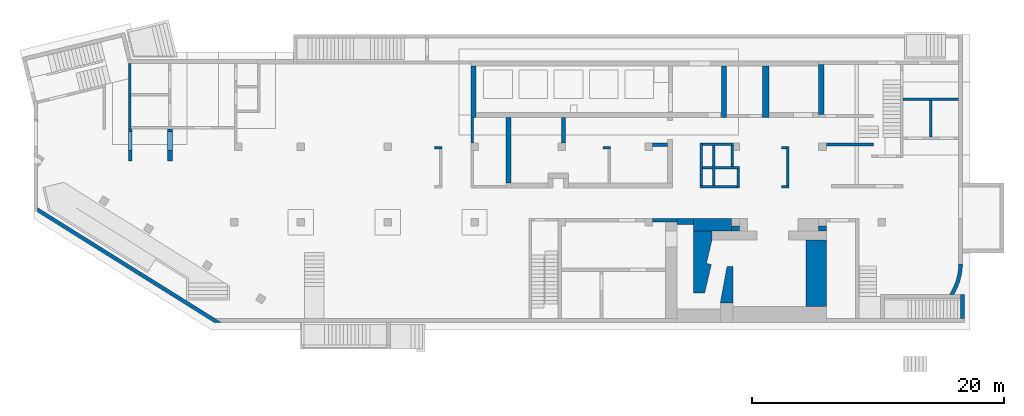
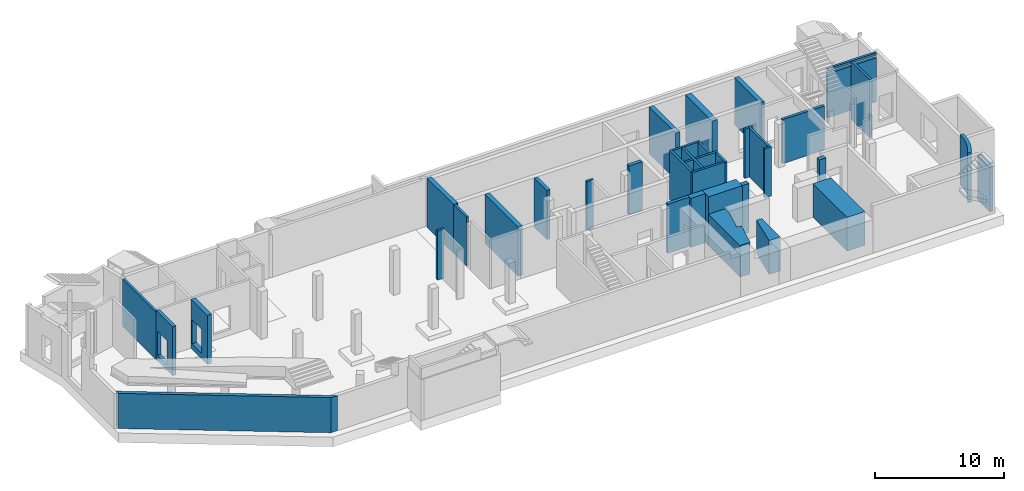
# One storey, part 3 of 9: 37 walls, 4 openings.
"""IFC4 building model written with IfcOpenShell, lengths in millimetres."""

from ifc_helpers import new_model, entity, si_unit, converted_unit, derived_unit, direction, frame, origin, place, context, subcontext, project, spatial, indexed_curve, outline, extrude, polygons, material, type_object, element, save


model = new_model("IFC4")

# Units and contexts
model_context = context("Model", 3, precision=0.01, world=origin(), true_north=direction((6.12303176911189e-17, 1.0)))
plan_context = context("Plan", 3, precision=0.01, world=origin(), true_north=direction((6.12303176911189e-17, 1.0)))
body_context = subcontext(model_context, "Body", "Model", "MODEL_VIEW")
ifc_project = project(units=[si_unit("LENGTHUNIT", "METRE", prefix="MILLI"), si_unit("AREAUNIT", "SQUARE_METRE"), si_unit("VOLUMEUNIT", "CUBIC_METRE"), converted_unit("PLANEANGLEUNIT", "DEGREE", entity("IfcRatioMeasure", 0.0174532925199433), si_unit("PLANEANGLEUNIT", "RADIAN"), dimensions=[0, 0, 0, 0, 0, 0, 0]), si_unit("MASSUNIT", "GRAM", prefix="KILO"), derived_unit("MASSDENSITYUNIT", [(si_unit("MASSUNIT", "GRAM", prefix="KILO"), 1), (si_unit("LENGTHUNIT", "METRE"), -3)]), derived_unit("MOMENTOFINERTIAUNIT", [(si_unit("LENGTHUNIT", "METRE"), 4)]), si_unit("TIMEUNIT", "SECOND"), si_unit("FREQUENCYUNIT", "HERTZ"), si_unit("THERMODYNAMICTEMPERATUREUNIT", "DEGREE_CELSIUS"), derived_unit("THERMALTRANSMITTANCEUNIT", [(si_unit("MASSUNIT", "GRAM", prefix="KILO"), 1), (si_unit("THERMODYNAMICTEMPERATUREUNIT", "KELVIN"), -1), (si_unit("TIMEUNIT", "SECOND"), -3)]), derived_unit("VOLUMETRICFLOWRATEUNIT", [(si_unit("LENGTHUNIT", "METRE"), 3), (si_unit("TIMEUNIT", "SECOND"), -1)]), derived_unit("MASSFLOWRATEUNIT", [(si_unit("MASSUNIT", "GRAM", prefix="KILO"), 1), (si_unit("TIMEUNIT", "SECOND"), -1)]), derived_unit("ROTATIONALFREQUENCYUNIT", [(si_unit("TIMEUNIT", "SECOND"), -1)]), si_unit("ELECTRICCURRENTUNIT", "AMPERE"), si_unit("ELECTRICVOLTAGEUNIT", "VOLT"), si_unit("POWERUNIT", "WATT"), si_unit("FORCEUNIT", "NEWTON", prefix="KILO"), si_unit("ILLUMINANCEUNIT", "LUX"), si_unit("LUMINOUSFLUXUNIT", "LUMEN"), si_unit("LUMINOUSINTENSITYUNIT", "CANDELA"), derived_unit("USERDEFINED", [(si_unit("MASSUNIT", "GRAM", prefix="KILO"), -1), (si_unit("LENGTHUNIT", "METRE"), -2), (si_unit("TIMEUNIT", "SECOND"), 3), (si_unit("LUMINOUSFLUXUNIT", "LUMEN"), 1)]), derived_unit("LINEARVELOCITYUNIT", [(si_unit("LENGTHUNIT", "METRE"), 1), (si_unit("TIMEUNIT", "SECOND"), -1)]), si_unit("PRESSUREUNIT", "PASCAL"), derived_unit("USERDEFINED", [(si_unit("LENGTHUNIT", "METRE"), -2), (si_unit("MASSUNIT", "GRAM", prefix="KILO"), 1), (si_unit("TIMEUNIT", "SECOND"), -2)]), derived_unit("LINEARFORCEUNIT", [(si_unit("MASSUNIT", "GRAM", prefix="KILO"), 1), (si_unit("LENGTHUNIT", "METRE"), 1), (si_unit("TIMEUNIT", "SECOND"), -2), (si_unit("LENGTHUNIT", "METRE"), -1)]), derived_unit("PLANARFORCEUNIT", [(si_unit("MASSUNIT", "GRAM", prefix="KILO"), 1), (si_unit("LENGTHUNIT", "METRE"), 1), (si_unit("TIMEUNIT", "SECOND"), -2), (si_unit("LENGTHUNIT", "METRE"), -2)])], contexts=[model_context, plan_context])

# Site, building, storey
site_placement = place(None, origin())
site = spatial("IfcSite", under=ifc_project, at=site_placement, CompositionType="ELEMENT")
building_placement = place(site_placement, origin())
building = spatial("IfcBuilding", under=site, at=building_placement, CompositionType="ELEMENT")
storey_placement = place(building_placement, frame((0.0, 0.0, -4900.0)))
storey = spatial("IfcBuildingStorey", under=building, at=storey_placement, CompositionType="ELEMENT", Elevation=-4900.0)

# Wall, opening
ifc_material = material()
wall_type_1 = type_object("IfcWallType", PredefinedType="STANDARD")
wall_1_placement = place(storey_placement, frame((73370.0002685547, 17469.9992263554, 0.0), z_axis=(0.0, 0.0, 1.0), x_axis=(-1.0, 0.0, 0.0)))
wall_1 = element("IfcWall", 1, at=wall_1_placement, inside=storey, type_object=wall_type_1, material=ifc_material, PredefinedType="NOTDEFINED", context=body_context, shape_type="SweptSolid", body=[
    extrude(outline(indexed_curve([(4399.99999999998, 99.9999999999989), (-3.44548696094126e-13, 99.9999999999989), (3.44548696094126e-13, -99.9999999999989), (4399.99999999998, -99.9999999999989), (4399.99999999998, 99.9999999999989)], self_intersect=False)), origin(), (0.0, 0.0, 1.0), 4650.0),
])
opening_1_placement = place(storey_placement, frame((73370.0002685547, 17469.9992263554, 0.0), z_axis=(0.0, 0.0, 1.0), x_axis=(-1.0, 0.0, 0.0)))
element("IfcOpeningElement", 2, at=opening_1_placement, cuts=wall_1, PredefinedType="OPENING", context=body_context, shape_type="SweptSolid", body=[
    extrude(outline(indexed_curve([(-2199.99999999998, -100.0), (2199.99999999999, -100.0), (2199.99999999999, 100.0), (-2199.99999999999, 100.0), (-2199.99999999998, -100.0)], self_intersect=False)), frame((2200.0, 0.0, 4170.0)), (0.0, 0.0, 1.0), 250.0),
])

# Walls
wall_2_placement = place(storey_placement, frame((71170.0002685547, 14469.9992263559, -850.0), z_axis=(0.0, 0.0, 1.0), x_axis=(0.0, 1.0, 0.0)))
element("IfcWall", 3, at=wall_2_placement, inside=storey, type_object=wall_type_1, material=ifc_material, PredefinedType="NOTDEFINED", context=body_context, shape_type="SweptSolid", body=[
    extrude(outline(indexed_curve([(2899.99999999951, 100.000000000003), (-2.98721966703065e-13, 100.000000000003), (2.98721966703065e-13, -100.000000000003), (2899.99999999951, -100.000000000003), (2899.99999999951, 100.000000000003)], self_intersect=False)), origin(), (0.0, 0.0, 1.0), 5500.0),
])
wall_3_placement = place(storey_placement, frame((34770.0002685547, 15999.9992263561, 0.0), z_axis=(0.0, 0.0, 1.0), x_axis=(0.0, -1.0, 0.0)))
element("IfcWall", 4, at=wall_3_placement, inside=storey, type_object=wall_type_1, material=ifc_material, PredefinedType="NOTDEFINED", context=body_context, shape_type="SweptSolid", body=[
    extrude(outline(indexed_curve([(1999.99999999982, 99.9999999999989), (-2.16573425859696e-13, 99.9999999999989), (2.16573425859696e-13, -99.9999999999989), (1999.99999999982, -99.9999999999989), (1999.99999999982, 99.9999999999989)], self_intersect=False)), origin(), (0.0, 0.0, 1.0), 4650.0),
])
wall_4_placement = place(storey_placement, frame((59830.0002685547, 10624.999226356, 0.0), z_axis=(0.0, 0.0, 1.0), x_axis=(0.0, 1.0, 0.0)))
element("IfcWall", 5, at=wall_4_placement, inside=storey, type_object=wall_type_1, material=ifc_material, PredefinedType="NOTDEFINED", context=body_context, shape_type="SweptSolid", body=[
    extrude(outline(indexed_curve([(3075.0, 100.000000000004), (-3.08123216157509e-13, 100.000000000003), (3.08123216157509e-13, -100.000000000003), (3075.0, -100.000000000002), (3075.0, 100.000000000004)], self_intersect=False)), origin(), (0.0, 0.0, 1.0), 4650.0),
])
wall_5_placement = place(storey_placement, frame((59730.0002685547, 13599.999226356, 0.0), z_axis=(0.0, 0.0, 1.0), x_axis=(-1.0, 0.0, 0.0)))
element("IfcWall", 6, at=wall_5_placement, inside=storey, type_object=wall_type_1, material=ifc_material, PredefinedType="NOTDEFINED", context=body_context, shape_type="SweptSolid", body=[
    extrude(outline(indexed_curve([(400.000000000003, 99.9999999999983), (-9.28211303758498e-13, 99.9999999999989), (9.28211303758498e-13, -99.9999999999989), (400.000000000005, -99.9999999999995), (400.000000000003, 99.9999999999983)], self_intersect=False)), origin(), (0.0, 0.0, 1.0), 4650.0),
])
wall_6_placement = place(storey_placement, frame((59930.0002685546, 10524.999226356, 0.0), z_axis=(0.0, 0.0, 1.0), x_axis=(-1.0, 0.0, 0.0)))
element("IfcWall", 7, at=wall_6_placement, inside=storey, type_object=wall_type_1, material=ifc_material, PredefinedType="NOTDEFINED", context=body_context, shape_type="SweptSolid", body=[
    extrude(outline(indexed_curve([(600.00000000001, 99.999999999998), (-9.28211303758498e-13, 99.9999999999989), (9.28211303758498e-13, -99.9999999999989), (600.000000000012, -99.9999999999999), (600.00000000001, 99.999999999998)], self_intersect=False)), origin(), (0.0, 0.0, 1.0), 4650.0),
])
wall_7_placement = place(storey_placement, frame((55520.0002685546, 13899.9992263562, 0.0), z_axis=(0.0, 0.0, 1.0), x_axis=(-1.0, 0.0, 0.0)))
element("IfcWall", 8, at=wall_7_placement, inside=storey, type_object=wall_type_1, material=ifc_material, PredefinedType="NOTDEFINED", context=body_context, shape_type="SweptSolid", body=[
    extrude(outline(indexed_curve([(2470.00000000003, 100.000000000001), (-3.39529745858372e-13, 99.9999999999989), (3.39529745858372e-13, -99.9999999999989), (2470.00000000003, -99.999999999997), (2470.00000000003, 100.000000000001)], self_intersect=False)), origin(), (0.0, 0.0, 1.0), 4650.0),
])
wall_8_placement = place(storey_placement, frame((52950.0002685546, 13999.9992263562, 0.0), z_axis=(0.0, 0.0, 1.0), x_axis=(0.0, -1.0, 0.0)))
element("IfcWall", 9, at=wall_8_placement, inside=storey, type_object=wall_type_1, material=ifc_material, PredefinedType="NOTDEFINED", context=body_context, shape_type="SweptSolid", body=[
    extrude(outline(indexed_curve([(3375.00000000001, 100.000000000003), (0.0, 100.000000000003), (0.0, -100.000000000003), (3375.00000000001, -100.000000000003), (3375.00000000001, 100.000000000003)], self_intersect=False)), origin(), (0.0, 0.0, 1.0), 4650.0),
])
wall_9_placement = place(storey_placement, frame((53930.0002685546, 13799.9992263562, 0.0), z_axis=(0.0, 0.0, 1.0), x_axis=(0.0, -1.0, 0.0)))
element("IfcWall", 10, at=wall_9_placement, inside=storey, type_object=wall_type_1, material=ifc_material, PredefinedType="NOTDEFINED", context=body_context, shape_type="SweptSolid", body=[
    extrude(outline(indexed_curve([(3175.00000000001, 100.000000000003), (0.0, 100.000000000003), (0.0, -100.000000000003), (3175.00000000001, -100.000000000003), (3175.00000000001, 100.000000000003)], self_intersect=False)), origin(), (0.0, 0.0, 1.0), 4650.0),
])

# Wall, opening
wall_10_placement = place(storey_placement, frame((53050.0002685546, 12024.9992263562, 0.0)))
wall_10 = element("IfcWall", 11, at=wall_10_placement, inside=storey, type_object=wall_type_1, material=ifc_material, PredefinedType="NOTDEFINED", context=body_context, shape_type="SweptSolid", body=[
    extrude(outline(indexed_curve([(2920.00000000003, 99.9999999999989), (0.0, 99.9999999999989), (0.0, -99.9999999999989), (2920.00000000003, -99.9999999999989), (2920.00000000003, 99.9999999999989)], self_intersect=False)), origin(), (0.0, 0.0, 1.0), 4650.0),
])
opening_2_placement = place(storey_placement, frame((53050.0002685546, 12024.9992263562, 0.0)))
element("IfcOpeningElement", 12, at=opening_2_placement, cuts=wall_10, PredefinedType="OPENING", context=body_context, shape_type="SweptSolid", body=[
    extrude(outline(indexed_curve([(-2325.0, -100.000000000001), (2325.0, -100.000000000001), (2325.0, 99.9999999999989), (-2325.0, 99.9999999999989), (-2325.0, -100.000000000001)], self_intersect=False)), frame((780.0, 0.0, 2325.0), z_axis=(1.0, 0.0, 0.0), x_axis=(0.0, 0.0, -1.0)), (0.0, 0.0, 1.0), 199.999999999998),
])

# Walls
wall_11_placement = place(storey_placement, frame((55870.0002685546, 11924.9992263562, 0.0), z_axis=(0.0, 0.0, 1.0), x_axis=(0.0, -1.0, 0.0)))
element("IfcWall", 13, at=wall_11_placement, inside=storey, type_object=wall_type_1, material=ifc_material, PredefinedType="NOTDEFINED", context=body_context, shape_type="SweptSolid", body=[
    extrude(outline(indexed_curve([(1500.0, 100.000000000003), (0.0, 100.000000000003), (0.0, -100.000000000003), (1500.0, -100.000000000003), (1500.0, 100.000000000003)], self_intersect=False)), origin(), (0.0, 0.0, 1.0), 4650.0),
])
wall_12_placement = place(storey_placement, frame((55420.0002685546, 13799.9992263562, 0.0), z_axis=(0.0, 0.0, 1.0), x_axis=(0.0, -1.0, 0.0)))
element("IfcWall", 14, at=wall_12_placement, inside=storey, type_object=wall_type_1, material=ifc_material, PredefinedType="NOTDEFINED", context=body_context, shape_type="SweptSolid", body=[
    extrude(outline(indexed_curve([(1675.0, 100.000000000003), (0.0, 100.000000000003), (0.0, -100.000000000003), (1675.0, -100.000000000003), (1675.0, 100.000000000003)], self_intersect=False)), origin(), (0.0, 0.0, 1.0), 4650.0),
])
wall_13_placement = place(storey_placement, frame((55770.0002685547, 10524.9992263562, 0.0), z_axis=(0.0, 0.0, 1.0), x_axis=(-1.0, 0.0, 0.0)))
element("IfcWall", 15, at=wall_13_placement, inside=storey, type_object=wall_type_1, material=ifc_material, PredefinedType="NOTDEFINED", context=body_context, shape_type="SweptSolid", body=[
    extrude(outline(indexed_curve([(2920.00000000003, 99.9999999999989), (0.0, 99.9999999999989), (0.0, -99.9999999999989), (2920.00000000003, -99.9999999999989), (2920.00000000003, 99.9999999999989)], self_intersect=False)), origin(), (0.0, 0.0, 1.0), 4650.0),
])
wall_14_placement = place(storey_placement, frame((45770.0002685547, 13599.9992263561, 0.0), z_axis=(0.0, 0.0, 1.0), x_axis=(-1.0, 0.0, 0.0)))
element("IfcWall", 16, at=wall_14_placement, inside=storey, type_object=wall_type_1, material=ifc_material, PredefinedType="NOTDEFINED", context=body_context, shape_type="SweptSolid", body=[
    extrude(outline(indexed_curve([(600.000000000001, 99.9999999999989), (-1.08286712929837e-12, 99.9999999999989), (1.08286712929837e-12, -99.9999999999989), (600.000000000003, -99.9999999999989), (600.000000000001, 99.9999999999989)], self_intersect=False)), origin(), (0.0, 0.0, 1.0), 4650.0),
])
wall_15_placement = place(storey_placement, frame((32370.0002685547, 13599.9992263562, 0.0), z_axis=(0.0, 0.0, 1.0), x_axis=(-1.0, 0.0, 0.0)))
element("IfcWall", 17, at=wall_15_placement, inside=storey, type_object=wall_type_1, material=ifc_material, PredefinedType="NOTDEFINED", context=body_context, shape_type="SweptSolid", body=[
    extrude(outline(indexed_curve([(600.000000000001, 99.9999999999984), (-9.89300764987533e-13, 99.9999999999989), (9.89300764987533e-13, -99.9999999999989), (600.000000000003, -99.9999999999995), (600.000000000001, 99.9999999999984)], self_intersect=False)), origin(), (0.0, 0.0, 1.0), 4650.0),
])
wall_16_placement = place(storey_placement, frame((7600.00026855467, 20299.9992263564, 0.0), z_axis=(0.0, 0.0, 1.0), x_axis=(0.0, -1.0, 0.0)))
element("IfcWall", 18, at=wall_16_placement, inside=storey, type_object=wall_type_1, material=ifc_material, PredefinedType="NOTDEFINED", context=body_context, shape_type="Tessellation", body=[
    polygons([(0.0, -100.0, 0.0), (5200.00000000049, -99.9999999999999, 0.0), (5200.00000000049, -99.9999999999999, 4500.0), (0.0, -100.0, 4500.0), (5200.00000000049, 99.999999999999, 0.0), (5000.00000000049, 99.9999999999993, 0.0), (2600.0, 99.9999999999999, 0.0), (2400.0, 100.0, 0.0), (0.0, 99.9999999999997, 0.0), (0.0, 99.9999999999997, 4500.0), (5099.99936063356, 99.9999999999992, 4500.0), (5200.00000000049, 99.999999999999, 4500.0)], [[[1, 2, 3, 4]], [[5, 6, 7, 8, 9, 10, 11, 12]], [[2, 1, 9, 8, 7, 6, 5]], [[9, 1, 4, 10]], [[2, 5, 12, 3]], [[4, 3, 12, 11, 10]]], closed=True),
])
wall_type_2 = type_object("IfcWallType", PredefinedType="STANDARD")
wall_17_placement = place(storey_placement, frame((220.513494592849, 8728.24038904602, 0.0), z_axis=(0.0, 0.0, 1.0), x_axis=(0.848052743777572, -0.529911826412028, 0.0)))
element("IfcWall", 19, at=wall_17_placement, inside=storey, type_object=wall_type_2, material=ifc_material, PredefinedType="NOTDEFINED", context=body_context, shape_type="Tessellation", body=[
    polygons([(187.457147082002, -149.999999999999, 0.0), (16702.841510544, -150.000000000001, 0.0), (16702.841510544, -150.000000000001, 3330.0), (187.457147082001, -149.999999999999, 3330.0), (-1.08286712929839e-12, 150.000000000001, 0.0), (0.0, 150.000000000001, 3330.0), (16616.8193185591, 150.0, 3330.0), (17182.9512390927, 150.000000000001, 3330.0), (17182.9512390925, 149.999999999999, 0.0), (16616.8193185591, 150.000000000001, 0.0)], [[[1, 2, 3, 4]], [[5, 6, 7, 8, 9, 10]], [[2, 1, 5, 10, 9]], [[1, 4, 6, 5]], [[3, 2, 9, 8]], [[4, 3, 8, 7, 6]]], closed=True),
])
wall_18_placement = place(storey_placement, frame((49070.0002685546, 7849.99922635606, 0.0)))
element("IfcWall", 20, at=wall_18_placement, inside=storey, type_object=wall_type_2, material=ifc_material, PredefinedType="NOTDEFINED", context=body_context, shape_type="SweptSolid", body=[
    extrude(outline(indexed_curve([(1950.0, 150.000000000001), (-5.11333990909232e-13, 150.000000000001), (5.11333990909232e-13, -150.000000000001), (1950.0, -150.0), (1950.0, 150.000000000001)], self_intersect=False)), origin(), (0.0, 0.0, 1.0), 4650.0),
])
wall_19_placement = place(storey_placement, frame((73675.0002685546, 1944.99922635597, 0.0), z_axis=(0.0, 0.0, 1.0), x_axis=(0.0, -1.0, 0.0)))
element("IfcWall", 21, at=wall_19_placement, inside=storey, type_object=wall_type_2, material=ifc_material, PredefinedType="NOTDEFINED", context=body_context, shape_type="SweptSolid", body=[
    extrude(outline(indexed_curve([(1895.00000000003, 150.000000000001), (0.0, 150.000000000001), (0.0, -150.000000000001), (1895.00000000003, -150.000000000001), (1895.00000000003, 150.000000000001)], self_intersect=False)), origin(), (0.0, 0.0, 1.0), 4229.99999999996),
])
wall_20_placement = place(storey_placement, frame((49070.0002685547, 13849.9992263562, 0.0)))
element("IfcWall", 22, at=wall_20_placement, inside=storey, type_object=wall_type_2, material=ifc_material, PredefinedType="NOTDEFINED", context=body_context, shape_type="SweptSolid", body=[
    extrude(outline(indexed_curve([(1200.0, 150.000000000001), (-5.41433564649196e-13, 150.000000000001), (5.41433564649196e-13, -150.000000000001), (1200.00000000001, -150.000000000001), (1200.0, 150.000000000001)], self_intersect=False)), origin(), (0.0, 0.0, 1.0), 4650.0),
])
wall_21_placement = place(storey_placement, frame((42020.0002685547, 13999.9992263563, 0.0), z_axis=(0.0, 0.0, 1.0), x_axis=(0.0, 1.0, 0.0)))
element("IfcWall", 23, at=wall_21_placement, inside=storey, type_object=wall_type_2, material=ifc_material, PredefinedType="NOTDEFINED", context=body_context, shape_type="SweptSolid", body=[
    extrude(outline(indexed_curve([(1999.99999999982, 150.000000000001), (0.0, 150.000000000001), (0.0, -150.000000000001), (1999.99999999982, -150.000000000001), (1999.99999999982, 150.000000000001)], self_intersect=False)), origin(), (0.0, 0.0, 1.0), 4650.0),
])

# Wall, opening
wall_22_placement = place(storey_placement, frame((7650.00026855467, 15099.9992263559, 0.0), z_axis=(0.0, 0.0, 1.0), x_axis=(0.0, -1.0, 0.0)))
wall_22 = element("IfcWall", 24, at=wall_22_placement, inside=storey, type_object=wall_type_2, material=ifc_material, PredefinedType="NOTDEFINED", context=body_context, shape_type="Tessellation", body=[
    polygons([(0.0, -149.999999999999, 0.0), (2559.99999999952, -149.999999999999, 0.0), (2559.99999999952, -149.999999999999, 4650.0), (0.0, -149.999999999999, 4650.0), (0.0, -149.999999999999, 4500.0), (199.999999999524, -149.999999999999, 2829.99999999804), (1699.99999999952, -150.0, 2829.99999999805), (1699.99999999952, -150.0, 550.0), (199.999999999521, -149.999999999999, 550.0), (2559.99999999952, 150.000000000001, 0.0), (0.0, 150.000000000001, 0.0), (0.0, 150.000000000001, 4650.0), (2559.99999999952, 150.000000000001, 4650.0), (1699.99999999952, 150.0, 2829.99999999805), (199.999999999521, 150.000000000001, 2829.99999999804), (199.999999999521, 150.000000000001, 550.0), (1699.99999999952, 150.0, 550.0), (0.0, 50.0000000000028, 0.0), (0.0, 50.0000000000039, 4650.0)], [[[1, 2, 3, 4, 5], [6, 7, 8, 9]], [[10, 11, 12, 13], [14, 15, 16, 17]], [[2, 1, 18, 11, 10]], [[3, 2, 10, 13]], [[4, 3, 13, 12, 19]], [[1, 5, 4, 19, 12, 11, 18]], [[14, 7, 6, 15]], [[15, 6, 9, 16]], [[16, 9, 8, 17]], [[7, 14, 17, 8]]], closed=True),
])
opening_3_placement = place(wall_22_placement, frame((15099.9992263559, -7650.00026855467, 0.0), z_axis=(0.0, 0.0, 1.0), x_axis=(0.0, 1.0, 0.0)))
element("IfcOpeningElement", 25, at=opening_3_placement, cuts=wall_22, PredefinedType="OPENING", context=body_context, shape_type="SweptSolid", body=[
    extrude(outline(indexed_curve([(-1139.99999999902, -749.999999999998), (1139.99999999902, -749.999999999998), (1139.99999999902, 750.000000000001), (-1139.99999999902, 750.000000000001), (-1139.99999999902, -749.999999999998)], self_intersect=False)), frame((7400.00026855467, 14149.9992263564, 1690.0), z_axis=(1.0, 0.0, 0.0), x_axis=(0.0, 0.0, -1.0)), (0.0, 0.0, 1.0), 500.000000001943),
])

# Walls
wall_23_placement = place(storey_placement, frame((73520.0002685546, 4399.99922635546, 0.0)))
element("IfcWall", 26, at=wall_23_placement, inside=storey, type_object=wall_type_2, material=ifc_material, PredefinedType="NOTDEFINED", context=body_context, shape_type="SweptSolid", body=[
    extrude(outline(indexed_curve([(-542.136329488565, -2454.9999999995), (-413.330459406746, -2231.13461263897), (-297.016369515146, -2000.53171517602), (-193.545301320908, -1763.88767474322), (-103.229713391773, -1521.91710132026), (-26.3423378039082, -1275.350689778), (36.8846434456006, -1024.93301334981), (86.2602995743678, -771.420275193577), (121.635527581284, -515.578024833953), (142.9035025029, -258.178846380812), (150.000000000001, -2.55048707444416e-05), (-149.999999999992, 2.55047527119245e-05), (-157.705892452505, -260.292278133518), (-180.796490186139, -519.67286416129), (-219.190914727773, -777.233211023775), (-272.754683528757, -1032.07117284195), (-341.300181011307, -1283.29413932128), (-424.587315721797, -1530.02216226056), (-522.324361289021, -1771.39103770973), (-634.168978242002, -2006.55533298103), (-759.729413108203, -2234.69134791076), (-898.565870592014, -2454.99999999949), (-542.136329488565, -2454.9999999995)], self_intersect=False)), origin(), (0.0, 0.0, 1.0), 4750.0),
])
wall_type_3 = type_object("IfcWallType", PredefinedType="STANDARD")
wall_24_placement = place(storey_placement, frame((62870.0002685547, 13874.9992263562, 0.0)))
element("IfcWall", 27, at=wall_24_placement, inside=storey, type_object=wall_type_3, material=ifc_material, PredefinedType="NOTDEFINED", context=body_context, shape_type="SweptSolid", body=[
    extrude(outline(indexed_curve([(3759.99999999999, 124.999999999999), (-3.94184035522033e-13, 125.0), (3.94184035522033e-13, -125.0), (3759.99999999999, -125.000000000001), (3759.99999999999, 124.999999999999)], self_intersect=False)), origin(), (0.0, 0.0, 1.0), 4170.0),
])
wall_type_4 = type_object("IfcWallType", PredefinedType="STANDARD")
wall_25_placement = place(storey_placement, frame((52320.0002685546, 7499.99922635605, 0.0)))
element("IfcWall", 28, at=wall_25_placement, inside=storey, type_object=wall_type_4, material=ifc_material, PredefinedType="NOTDEFINED", context=body_context, shape_type="SweptSolid", body=[
    extrude(outline(indexed_curve([(3050.00000000001, 500.0), (-1.54352002599108e-12, 500.0), (1.54352002599108e-12, -500.0), (3050.00000000001, -500.0), (3050.00000000001, 500.0)], self_intersect=False)), origin(), (0.0, 0.0, 1.0), 4650.0),
])
wall_type_5 = type_object("IfcWallType", PredefinedType="NOTDEFINED", material=ifc_material)
wall_26_placement = place(storey_placement, frame((54470.0002685546, 1299.99922635607, 0.0), z_axis=(0.0, 0.0, 1.0), x_axis=(0.0, 1.0, 0.0)))
element("IfcWall", 29, at=wall_26_placement, inside=storey, type_object=wall_type_5, material=ifc_material, PredefinedType="NOTDEFINED", context=body_context, shape_type="SweptSolid", body=[
    extrude(outline(indexed_curve([(-368.249999999999, -1450.0), (104.749999999998, -1450.0), (631.749999999999, 1450.0), (-368.249999999999, 1450.0), (-368.249999999999, -1450.0)], self_intersect=False)), frame((1450.0, -631.749999999999, 0.0), z_axis=(0.0, 0.0, 1.0), x_axis=(0.0, 1.0, 0.0)), (0.0, 0.0, 1.0), 3200.0),
])
wall_type_6 = type_object("IfcWallType", PredefinedType="STANDARD")
wall_27_placement = place(storey_placement, frame((50570.0002685546, 7749.99922635606, 0.0)))
element("IfcWall", 30, at=wall_27_placement, inside=storey, type_object=wall_type_6, material=ifc_material, PredefinedType="NOTDEFINED", context=body_context, shape_type="SweptSolid", body=[
    extrude(outline(indexed_curve([(1750.0, -250.000000000001), (1750.0, 249.999999999999), (450.000000000001, 249.999999999999), (450.000000000002, -50.0000000000001), (450.000000000002, -250.000000000001), (1750.0, -250.000000000001)], self_intersect=False)), origin(), (0.0, 0.0, 1.0), 4650.0),
])
wall_28_placement = place(storey_placement, frame((58070.0002685547, 20099.999226356, 0.0), z_axis=(0.0, 0.0, 1.0), x_axis=(0.0, -1.0, 0.0)))
element("IfcWall", 31, at=wall_28_placement, inside=storey, type_object=wall_type_6, material=ifc_material, PredefinedType="NOTDEFINED", context=body_context, shape_type="SweptSolid", body=[
    extrude(outline(indexed_curve([(4100.00000000002, 250.000000000004), (0.0, 250.000000000004), (0.0, -250.000000000004), (4100.00000000002, -250.000000000004), (4100.00000000002, 250.000000000004)], self_intersect=False)), origin(), (0.0, 0.0, 1.0), 4450.0),
])
wall_type_7 = type_object("IfcWallType", PredefinedType="STANDARD")
wall_29_placement = place(storey_placement, frame((55370.0002685547, 7199.99922635604, 0.0)))
element("IfcWall", 32, at=wall_29_placement, inside=storey, type_object=wall_type_7, material=ifc_material, PredefinedType="NOTDEFINED", context=body_context, shape_type="SweptSolid", body=[
    extrude(outline(indexed_curve([(600.000000000001, 200.0), (-1.44382283906452e-12, 200.0), (1.44382283906452e-12, -200.0), (600.000000000004, -200.0), (600.000000000001, 200.0)], self_intersect=False)), origin(), (0.0, 0.0, 1.0), 4650.0),
])
wall_30_placement = place(storey_placement, frame((62270.0002685546, 7199.99922635602, 0.0)))
element("IfcWall", 33, at=wall_30_placement, inside=storey, type_object=wall_type_7, material=ifc_material, PredefinedType="NOTDEFINED", context=body_context, shape_type="SweptSolid", body=[
    extrude(outline(indexed_curve([(600.000000000001, 200.0), (-7.21911419532259e-13, 200.0), (7.21911419532259e-13, -200.0), (600.000000000003, -200.0), (600.000000000001, 200.0)], self_intersect=False)), origin(), (0.0, 0.0, 1.0), 4650.0),
])
wall_31_placement = place(storey_placement, frame((62470.0002685547, 20499.999226356, 0.0), z_axis=(0.0, 0.0, 1.0), x_axis=(0.0, -1.0, 0.0)))
element("IfcWall", 34, at=wall_31_placement, inside=storey, type_object=wall_type_7, material=ifc_material, PredefinedType="NOTDEFINED", context=body_context, shape_type="SweptSolid", body=[
    extrude(outline(indexed_curve([(4250.00000000001, -199.999999999993), (4250.00000000001, 200.000000000003), (300.000000000005, 199.999999999999), (300.000000000006, -199.999999999997), (400.000000000001, -199.999999999997), (4100.00000000001, -199.999999999993), (4250.00000000001, -199.999999999993)], self_intersect=False)), origin(), (0.0, 0.0, 1.0), 4450.0),
])
wall_32_placement = place(storey_placement, frame((34870.0002685547, 20499.9992263561, 0.0), z_axis=(0.0, 0.0, 1.0), x_axis=(0.0, -1.0, 0.0)))
element("IfcWall", 35, at=wall_32_placement, inside=storey, type_object=wall_type_7, material=ifc_material, PredefinedType="NOTDEFINED", context=body_context, shape_type="SweptSolid", body=[
    extrude(outline(indexed_curve([(4500.00000000001, -199.999999999998), (4500.00000000001, 0.0), (4500.00000000001, 200.000000000002), (4100.00000000001, 200.000000000002), (400.0, 200.000000000002), (399.999999999996, -199.999999999998), (4500.00000000001, -199.999999999998)], self_intersect=False)), origin(), (0.0, 0.0, 1.0), 4650.0),
])
wall_33_placement = place(storey_placement, frame((54770.0002685547, 20099.999226356, 0.0), z_axis=(0.0, 0.0, 1.0), x_axis=(0.0, -1.0, 0.0)))
element("IfcWall", 36, at=wall_33_placement, inside=storey, type_object=wall_type_7, material=ifc_material, PredefinedType="NOTDEFINED", context=body_context, shape_type="SweptSolid", body=[
    extrude(outline(indexed_curve([(4100.00000000001, 199.999999999998), (0.0, 199.999999999998), (0.0, -199.999999999998), (4100.00000000001, -199.999999999998), (4100.00000000001, 199.999999999998)], self_intersect=False)), origin(), (0.0, 0.0, 1.0), 4450.0),
])
wall_34_placement = place(storey_placement, frame((37665.0002685547, 10824.9992263562, 0.0), z_axis=(0.0, 0.0, 1.0), x_axis=(0.0, 1.0, 0.0)))
element("IfcWall", 37, at=wall_34_placement, inside=storey, type_object=wall_type_7, material=ifc_material, PredefinedType="NOTDEFINED", context=body_context, shape_type="SweptSolid", body=[
    extrude(outline(indexed_curve([(5174.99999999991, 199.999999999996), (-4.14990995659274e-13, 199.999999999998), (4.14990995659274e-13, -199.999999999998), (5174.99999999991, -200.0), (5174.99999999991, 199.999999999996)], self_intersect=False)), origin(), (0.0, 0.0, 1.0), 4650.0),
])

# Wall, opening
wall_35_placement = place(storey_placement, frame((10800.0002685547, 12539.9992263564, 0.0), z_axis=(0.0, 0.0, 1.0), x_axis=(0.0, 1.0, 0.0)))
wall_35 = element("IfcWall", 38, at=wall_35_placement, inside=storey, type_object=wall_type_7, material=ifc_material, PredefinedType="NOTDEFINED", context=body_context, shape_type="Tessellation", body=[
    polygons([(0.0, -200.000000000001, 0.0), (2559.99999999951, -200.0, 0.0), (2559.99999999951, -200.0, 4650.0), (0.0, -200.000000000001, 4650.0), (860.000000000004, -200.000000000001, 2829.99999999804), (2360.0, -200.000000000001, 2829.99999999805), (2360.0, -200.000000000001, 550.0), (860.000000000002, -200.000000000001, 550.0), (2559.99999999951, 200.0, 0.0), (0.0, 199.999999999999, 0.0), (0.0, 199.999999999999, 4650.0), (2559.99999999951, 200.0, 4650.0), (2360.0, 199.999999999999, 2829.99999999805), (860.000000000006, 199.999999999999, 2829.99999999804), (860.000000000002, 199.999999999999, 550.0), (2360.0, 199.999999999999, 550.0)], [[[1, 2, 3, 4], [5, 6, 7, 8]], [[9, 10, 11, 12], [13, 14, 15, 16]], [[2, 1, 10, 9]], [[4, 3, 12, 11]], [[1, 4, 11, 10]], [[3, 2, 9, 12]], [[13, 6, 5, 14]], [[14, 5, 8, 15]], [[15, 8, 7, 16]], [[6, 13, 16, 7]]], closed=True),
])
opening_4_placement = place(wall_35_placement, frame((-12539.9992263564, 10800.0002685547, 0.0), z_axis=(0.0, 0.0, 1.0), x_axis=(0.0, -1.0, 0.0)))
element("IfcOpeningElement", 39, at=opening_4_placement, cuts=wall_35, PredefinedType="OPENING", context=body_context, shape_type="SweptSolid", body=[
    extrude(outline(indexed_curve([(-1139.99999999902, -750.000000000001), (1139.99999999902, -750.000000000001), (1139.99999999902, 749.999999999998), (-1139.99999999902, 749.999999999998), (-1139.99999999902, -750.000000000001)], self_intersect=False)), frame((11100.0002685547, 14149.9992263564, 1690.0), z_axis=(-1.0, 0.0, 0.0), x_axis=(0.0, 0.0, -1.0)), (0.0, 0.0, 1.0), 600.000000001943),
])

# Walls
wall_type_8 = type_object("IfcWallType", PredefinedType="NOTDEFINED", material=ifc_material)
wall_36_placement = place(storey_placement, frame((52320.0002685546, 2099.99922635609, 0.0), z_axis=(0.0, 0.0, 1.0), x_axis=(0.0, 1.0, 0.0)))
element("IfcWall", 40, at=wall_36_placement, inside=storey, type_object=wall_type_8, material=ifc_material, PredefinedType="NOTDEFINED", context=body_context, shape_type="SweptSolid", body=[
    extrude(outline(indexed_curve([(-905.604757595647, -2654.02109078585), (-5.60475759564329, -2654.02109078585), (525.395242404358, -411.021090785853), (136.153912030035, -318.873455284841), (577.632559176254, 1545.97890921415), (577.632559176254, 2245.97890921412), (-905.604757595645, 2245.97890921412), (-905.604757595647, -2654.02109078585)], self_intersect=False)), frame((2654.02109078585, -905.604757595646, 0.0), z_axis=(0.0, 0.0, 1.0), x_axis=(0.0, -1.0, 0.0)), (0.0, 0.0, 1.0), 3000.0),
])
wall_type_9 = type_object("IfcWallType", PredefinedType="STANDARD")
wall_37_placement = place(storey_placement, frame((62070.0002685546, 999.999226356019, 0.0), z_axis=(0.0, 0.0, 1.0), x_axis=(0.0, 1.0, 0.0)))
element("IfcWall", 41, at=wall_37_placement, inside=storey, type_object=wall_type_9, material=ifc_material, PredefinedType="NOTDEFINED", context=body_context, shape_type="SweptSolid", body=[
    extrude(outline(indexed_curve([(-799.999999999991, -2650.0), (800.000000000009, -2650.0), (799.999999999991, 2650.0), (-800.000000000009, 2650.00000000001), (-799.999999999991, -2650.0)], self_intersect=False)), frame((2650.0, 0.0, 0.0), z_axis=(0.0, 0.0, 1.0), x_axis=(0.0, 1.0, 0.0)), (0.0, 0.0, 1.0), 3200.0),
])

save(model, "model.ifc")
